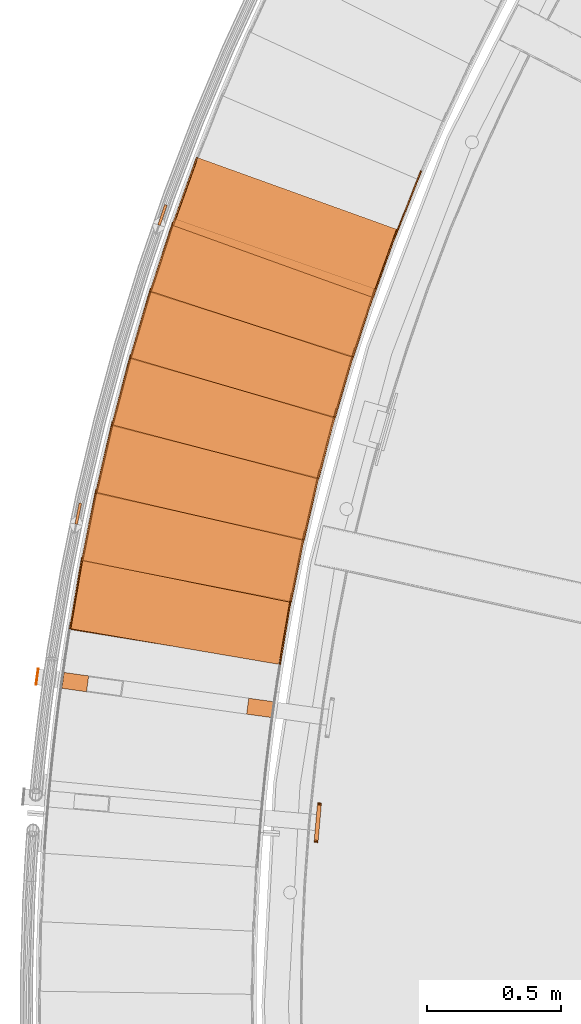
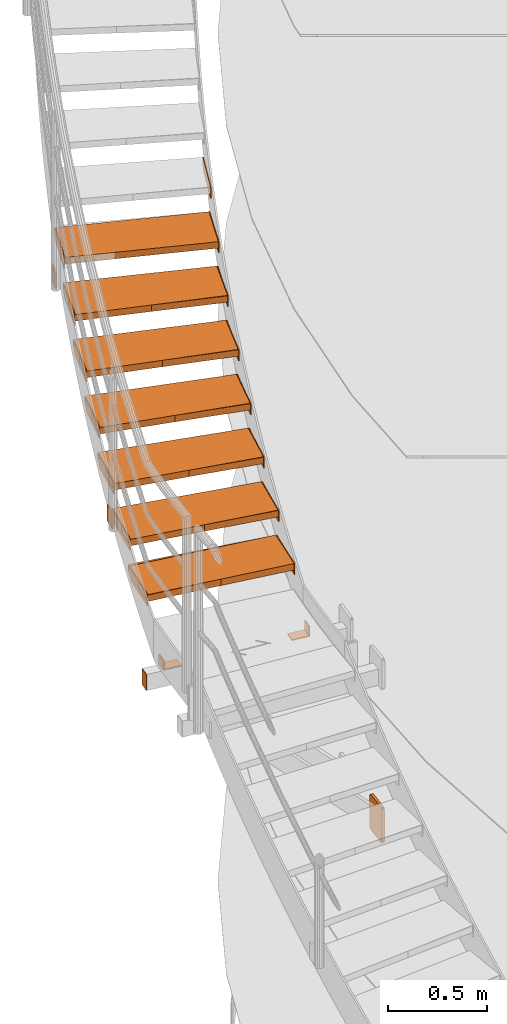
# One storey, part 61 of 126: 34 proxies.
"""IFC2X3 building model written with IfcOpenShell, lengths in millimetres."""

from ifc_helpers import new_model, si_unit, origin, origin_with_axes, place, context, project, spatial, faceted_brep, material, element, save


model = new_model("IFC2X3")

# Units and contexts
context_of_model_1 = context(None, 3, precision=0.1, world=origin())
context_of_model_2 = context(None, 3, precision=0.1, world=origin())
ifc_project = project(units=[si_unit("LENGTHUNIT", "METRE", prefix="MILLI"), si_unit("AREAUNIT", "SQUARE_METRE", prefix="CENTI"), si_unit("VOLUMEUNIT", "CUBIC_METRE", prefix="CENTI"), si_unit("MASSUNIT", "GRAM", prefix="KILO")], contexts=[context_of_model_1, context_of_model_2])

# Site, building, storey
site_placement = place(None, origin_with_axes())
site = spatial("IfcSite", under=ifc_project, at=site_placement, CompositionType="ELEMENT")
building_placement = place(site_placement, origin_with_axes())
building = spatial("IfcBuilding", under=site, at=building_placement, CompositionType="ELEMENT")
storey_placement = place(building_placement, origin_with_axes())
storey = spatial("IfcBuildingStorey", under=building, at=storey_placement, CompositionType="ELEMENT")

# Proxies
ifc_material_1 = material(Name="HOLZ")
proxy_1_placement = place(storey_placement, origin_with_axes())
element("IfcBuildingElementProxy", 1, at=proxy_1_placement, inside=storey, material=ifc_material_1, context=context_of_model_2, shape_type="Brep", body=[
    faceted_brep([(-647.8972, 9698.1797, 5715.8062), (-652.9137, 9672.3391, 5715.8062), (-657.8529, 9646.4836, 5715.8062), (-662.7149, 9620.6135, 5715.8062), (-667.4997, 9594.7289, 5715.8062), (-672.2071, 9568.8303, 5715.8062), (-676.8373, 9542.9176, 5715.8062), (-681.39, 9516.9913, 5715.8062), (-685.8653, 9491.0515, 5715.8062), (-690.2632, 9465.0984, 5715.8062), (-694.5835, 9439.1323, 5715.8062), (-698.8263, 9413.1535, 5715.8062), (90.905, 9285.3862, 5715.8062), (95.1968, 9311.638, 5715.8062), (99.5758, 9337.8754, 5715.8062), (104.0418, 9364.0982, 5715.8062), (108.5947, 9390.306, 5715.8062), (113.2346, 9416.4985, 5715.8062), (117.9614, 9442.6755, 5715.8062), (122.775, 9468.8366, 5715.8062), (127.6754, 9494.9817, 5715.8062), (132.6625, 9521.1103, 5715.8062), (137.7362, 9547.2223, 5715.8062), (-647.8972, 9698.1797, 5675.8062), (137.7362, 9547.2223, 5675.8062), (132.6625, 9521.1103, 5675.8062), (127.6754, 9494.9817, 5675.8062), (122.775, 9468.8366, 5675.8062), (117.9614, 9442.6755, 5675.8062), (113.2346, 9416.4985, 5675.8062), (108.5947, 9390.306, 5675.8062), (104.0418, 9364.0982, 5675.8062), (99.5758, 9337.8754, 5675.8062), (95.1968, 9311.638, 5675.8062), (90.905, 9285.3862, 5675.8062), (-698.8263, 9413.1535, 5675.8062), (-694.5835, 9439.1323, 5675.8062), (-690.2632, 9465.0984, 5675.8062), (-685.8653, 9491.0515, 5675.8062), (-681.39, 9516.9913, 5675.8062), (-676.8373, 9542.9176, 5675.8062), (-672.2071, 9568.8303, 5675.8062), (-667.4997, 9594.7289, 5675.8062), (-662.7149, 9620.6135, 5675.8062), (-657.8529, 9646.4836, 5675.8062), (-652.9137, 9672.3391, 5675.8062)], [[[0, 1, 2, 3, 4, 5, 6, 7, 8, 9, 10, 11, 12, 13, 14, 15, 16, 17, 18, 19, 20, 21, 22]], [[23, 24, 25, 26, 27, 28, 29, 30, 31, 32, 33, 34, 35, 36, 37, 38, 39, 40, 41, 42, 43, 44, 45]], [[0, 23, 45, 1]], [[1, 45, 44, 2]], [[2, 44, 43, 3]], [[3, 43, 42, 4]], [[4, 42, 41, 5]], [[5, 41, 40, 6]], [[6, 40, 39, 7]], [[7, 39, 38, 8]], [[8, 38, 37, 9]], [[9, 37, 36, 10]], [[10, 36, 35, 11]], [[11, 35, 34, 12]], [[12, 34, 33, 13]], [[13, 33, 32, 14]], [[14, 32, 31, 15]], [[15, 31, 30, 16]], [[16, 30, 29, 17]], [[17, 29, 28, 18]], [[18, 28, 27, 19]], [[19, 27, 26, 20]], [[20, 26, 25, 21]], [[21, 25, 24, 22]], [[22, 24, 23, 0]]]),
])
proxy_2_placement = place(storey_placement, origin_with_axes())
element("IfcBuildingElementProxy", 2, at=proxy_2_placement, inside=storey, material=ifc_material_1, context=context_of_model_2, shape_type="Brep", body=[
    faceted_brep([(-594.3119, 9952.1321, 5889.0125), (-600.0867, 9926.4503, 5889.0125), (-605.7848, 9900.7514, 5889.0125), (-611.4062, 9875.0356, 5889.0125), (-616.9507, 9849.3031, 5889.0125), (-622.4184, 9823.5542, 5889.0125), (-627.8093, 9797.7891, 5889.0125), (-633.1231, 9772.008, 5889.0125), (-638.36, 9746.2111, 5889.0125), (-643.5198, 9720.3987, 5889.0125), (-648.6026, 9694.5711, 5889.0125), (-653.6082, 9668.7283, 5889.0125), (132.0203, 9517.7718, 5889.0125), (137.083, 9543.8859, 5889.0125), (142.2323, 9569.9831, 5889.0125), (147.4681, 9596.063, 5889.0125), (152.7905, 9622.1254, 5889.0125), (158.1993, 9648.17, 5889.0125), (163.6946, 9674.1966, 5889.0125), (169.2761, 9700.2047, 5889.0125), (174.9439, 9726.1942, 5889.0125), (180.6979, 9752.1647, 5889.0125), (186.538, 9778.116, 5889.0125), (-594.3119, 9952.1321, 5849.0125), (186.538, 9778.116, 5849.0125), (180.6979, 9752.1647, 5849.0125), (174.9439, 9726.1942, 5849.0125), (169.2761, 9700.2047, 5849.0125), (163.6946, 9674.1966, 5849.0125), (158.1993, 9648.17, 5849.0125), (152.7905, 9622.1254, 5849.0125), (147.4681, 9596.063, 5849.0125), (142.2323, 9569.9831, 5849.0125), (137.083, 9543.8859, 5849.0125), (132.0203, 9517.7718, 5849.0125), (-653.6082, 9668.7283, 5849.0125), (-648.6026, 9694.5711, 5849.0125), (-643.5198, 9720.3987, 5849.0125), (-638.36, 9746.2111, 5849.0125), (-633.1231, 9772.008, 5849.0125), (-627.8093, 9797.7891, 5849.0125), (-622.4184, 9823.5542, 5849.0125), (-616.9507, 9849.3031, 5849.0125), (-611.4062, 9875.0356, 5849.0125), (-605.7848, 9900.7514, 5849.0125), (-600.0867, 9926.4503, 5849.0125)], [[[0, 1, 2, 3, 4, 5, 6, 7, 8, 9, 10, 11, 12, 13, 14, 15, 16, 17, 18, 19, 20, 21, 22]], [[23, 24, 25, 26, 27, 28, 29, 30, 31, 32, 33, 34, 35, 36, 37, 38, 39, 40, 41, 42, 43, 44, 45]], [[0, 23, 45, 1]], [[1, 45, 44, 2]], [[2, 44, 43, 3]], [[3, 43, 42, 4]], [[4, 42, 41, 5]], [[5, 41, 40, 6]], [[6, 40, 39, 7]], [[7, 39, 38, 8]], [[8, 38, 37, 9]], [[9, 37, 36, 10]], [[10, 36, 35, 11]], [[11, 35, 34, 12]], [[12, 34, 33, 13]], [[13, 33, 32, 14]], [[14, 32, 31, 15]], [[15, 31, 30, 16]], [[16, 30, 29, 17]], [[17, 29, 28, 18]], [[18, 28, 27, 19]], [[19, 27, 26, 20]], [[20, 26, 25, 21]], [[21, 25, 24, 22]], [[22, 24, 23, 0]]]),
])
proxy_3_placement = place(storey_placement, origin_with_axes())
element("IfcBuildingElementProxy", 3, at=proxy_3_placement, inside=storey, material=ifc_material_1, context=context_of_model_2, shape_type="Brep", body=[
    faceted_brep([(-533.275, 10204.397, 6062.2188), (-539.8032, 10178.897, 6062.2188), (-546.2552, 10153.377, 6062.2188), (-552.6311, 10127.837, 6062.2188), (-558.9306, 10102.279, 6062.2188), (-565.1539, 10076.702, 6062.2188), (-571.3007, 10051.107, 6062.2188), (-577.3711, 10025.494, 6062.2188), (-583.365, 9999.8619, 6062.2188), (-589.2824, 9974.2126, 6062.2188), (-595.1231, 9948.5458, 6062.2188), (-600.8872, 9922.8616, 6062.2188), (179.9577, 9748.8466, 6062.2188), (185.7868, 9774.8004, 6062.2188), (191.702, 9800.7347, 6062.2188), (197.7033, 9826.6492, 6062.2188), (203.7905, 9852.5436, 6062.2188), (209.9635, 9878.4178, 6062.2188), (216.2224, 9904.2713, 6062.2188), (222.567, 9930.1038, 6062.2188), (228.9973, 9955.9152, 6062.2188), (235.5132, 9981.7052, 6062.2188), (242.1147, 10007.473, 6062.2188), (-533.275, 10204.397, 6022.2188), (242.1147, 10007.473, 6022.2188), (235.5132, 9981.7052, 6022.2188), (228.9973, 9955.9152, 6022.2188), (222.567, 9930.1038, 6022.2188), (216.2224, 9904.2713, 6022.2188), (209.9635, 9878.4178, 6022.2188), (203.7905, 9852.5436, 6022.2188), (197.7033, 9826.6492, 6022.2188), (191.702, 9800.7347, 6022.2188), (185.7868, 9774.8004, 6022.2188), (179.9577, 9748.8466, 6022.2188), (-600.8872, 9922.8616, 6022.2188), (-595.1231, 9948.5458, 6022.2188), (-589.2824, 9974.2126, 6022.2188), (-583.365, 9999.8619, 6022.2188), (-577.3711, 10025.494, 6022.2188), (-571.3007, 10051.107, 6022.2188), (-565.1539, 10076.702, 6022.2188), (-558.9306, 10102.279, 6022.2188), (-552.6311, 10127.837, 6022.2188), (-546.2552, 10153.377, 6022.2188), (-539.8032, 10178.897, 6022.2188)], [[[0, 1, 2, 3, 4, 5, 6, 7, 8, 9, 10, 11, 12, 13, 14, 15, 16, 17, 18, 19, 20, 21, 22]], [[23, 24, 25, 26, 27, 28, 29, 30, 31, 32, 33, 34, 35, 36, 37, 38, 39, 40, 41, 42, 43, 44, 45]], [[0, 23, 45, 1]], [[1, 45, 44, 2]], [[2, 44, 43, 3]], [[3, 43, 42, 4]], [[4, 42, 41, 5]], [[5, 41, 40, 6]], [[6, 40, 39, 7]], [[7, 39, 38, 8]], [[8, 38, 37, 9]], [[9, 37, 36, 10]], [[10, 36, 35, 11]], [[11, 35, 34, 12]], [[12, 34, 33, 13]], [[13, 33, 32, 14]], [[14, 32, 31, 15]], [[15, 31, 30, 16]], [[16, 30, 29, 17]], [[17, 29, 28, 18]], [[18, 28, 27, 19]], [[19, 27, 26, 20]], [[20, 26, 25, 21]], [[21, 25, 24, 22]], [[22, 24, 23, 0]]]),
])
proxy_4_placement = place(storey_placement, origin_with_axes())
element("IfcBuildingElementProxy", 4, at=proxy_4_placement, inside=storey, material=ifc_material_1, context=context_of_model_2, shape_type="Brep", body=[
    faceted_brep([(-464.8394, 10454.757, 6235.425), (-472.1154, 10429.459, 6235.425), (-479.3158, 10404.14, 6235.425), (-486.4406, 10378.799, 6235.425), (-493.4897, 10353.438, 6235.425), (-500.4631, 10328.055, 6235.425), (-507.3606, 10302.652, 6235.425), (-514.1823, 10277.228, 6235.425), (-520.928, 10251.784, 6235.425), (-527.5977, 10226.32, 6235.425), (-534.1914, 10200.836, 6235.425), (-540.709, 10175.333, 6235.425), (234.6757, 9978.4103, 6235.425), (241.2662, 10004.181, 6235.425), (247.9422, 10029.93, 6235.425), (254.7036, 10055.657, 6235.425), (261.5503, 10081.361, 6235.425), (268.4823, 10107.042, 6235.425), (275.4994, 10132.7, 6235.425), (282.6016, 10158.335, 6235.425), (289.7889, 10183.946, 6235.425), (297.0611, 10209.533, 6235.425), (304.4181, 10235.095, 6235.425), (-464.8394, 10454.757, 6195.425), (304.4181, 10235.095, 6195.425), (297.0611, 10209.533, 6195.425), (289.7889, 10183.946, 6195.425), (282.6016, 10158.335, 6195.425), (275.4994, 10132.7, 6195.425), (268.4823, 10107.042, 6195.425), (261.5503, 10081.361, 6195.425), (254.7036, 10055.657, 6195.425), (247.9422, 10029.93, 6195.425), (241.2662, 10004.181, 6195.425), (234.6757, 9978.4103, 6195.425), (-540.709, 10175.333, 6195.425), (-534.1914, 10200.836, 6195.425), (-527.5977, 10226.32, 6195.425), (-520.928, 10251.784, 6195.425), (-514.1823, 10277.228, 6195.425), (-507.3606, 10302.652, 6195.425), (-500.4631, 10328.055, 6195.425), (-493.4897, 10353.438, 6195.425), (-486.4406, 10378.799, 6195.425), (-479.3158, 10404.14, 6195.425), (-472.1154, 10429.459, 6195.425)], [[[0, 1, 2, 3, 4, 5, 6, 7, 8, 9, 10, 11, 12, 13, 14, 15, 16, 17, 18, 19, 20, 21, 22]], [[23, 24, 25, 26, 27, 28, 29, 30, 31, 32, 33, 34, 35, 36, 37, 38, 39, 40, 41, 42, 43, 44, 45]], [[0, 23, 45, 1]], [[1, 45, 44, 2]], [[2, 44, 43, 3]], [[3, 43, 42, 4]], [[4, 42, 41, 5]], [[5, 41, 40, 6]], [[6, 40, 39, 7]], [[7, 39, 38, 8]], [[8, 38, 37, 9]], [[9, 37, 36, 10]], [[10, 36, 35, 11]], [[11, 35, 34, 12]], [[12, 34, 33, 13]], [[13, 33, 32, 14]], [[14, 32, 31, 15]], [[15, 31, 30, 16]], [[16, 30, 29, 17]], [[17, 29, 28, 18]], [[18, 28, 27, 19]], [[19, 27, 26, 20]], [[20, 26, 25, 21]], [[21, 25, 24, 22]], [[22, 24, 23, 0]]]),
])
proxy_5_placement = place(storey_placement, origin_with_axes())
element("IfcBuildingElementProxy", 5, at=proxy_5_placement, inside=storey, material=ifc_material_1, context=context_of_model_2, shape_type="Brep", body=[
    faceted_brep([(-389.0646, 10702.993, 6408.6313), (-397.082, 10677.921, 6408.6313), (-405.0245, 10652.825, 6408.6313), (-412.8921, 10627.705, 6408.6313), (-420.6846, 10602.562, 6408.6313), (-428.4021, 10577.395, 6408.6313), (-436.0443, 10552.206, 6408.6313), (-443.6113, 10526.994, 6408.6313), (-451.1031, 10501.76, 6408.6313), (-458.5194, 10476.503, 6408.6313), (-465.8603, 10451.224, 6408.6313), (-473.1257, 10425.924, 6408.6313), (296.1269, 10206.264, 6408.6313), (303.4731, 10231.83, 6408.6313), (310.9041, 10257.371, 6408.6313), (318.4198, 10282.888, 6408.6313), (326.0201, 10308.379, 6408.6313), (333.7049, 10333.845, 6408.6313), (341.4742, 10359.285, 6408.6313), (349.3279, 10384.7, 6408.6313), (357.2658, 10410.088, 6408.6313), (365.288, 10435.45, 6408.6313), (373.3942, 10460.785, 6408.6313), (-389.0646, 10702.993, 6368.6313), (373.3942, 10460.785, 6368.6313), (365.288, 10435.45, 6368.6313), (357.2658, 10410.088, 6368.6313), (349.3279, 10384.7, 6368.6313), (341.4742, 10359.285, 6368.6313), (333.7049, 10333.845, 6368.6313), (326.0201, 10308.379, 6368.6313), (318.4198, 10282.888, 6368.6313), (310.9041, 10257.371, 6368.6313), (303.4731, 10231.83, 6368.6313), (296.1269, 10206.264, 6368.6313), (-473.1257, 10425.924, 6368.6313), (-465.8603, 10451.224, 6368.6313), (-458.5194, 10476.503, 6368.6313), (-451.1031, 10501.76, 6368.6313), (-443.6113, 10526.994, 6368.6313), (-436.0443, 10552.206, 6368.6313), (-428.4021, 10577.395, 6368.6313), (-420.6846, 10602.562, 6368.6313), (-412.8921, 10627.705, 6368.6313), (-405.0245, 10652.825, 6368.6313), (-397.082, 10677.921, 6368.6313)], [[[0, 1, 2, 3, 4, 5, 6, 7, 8, 9, 10, 11, 12, 13, 14, 15, 16, 17, 18, 19, 20, 21, 22]], [[23, 24, 25, 26, 27, 28, 29, 30, 31, 32, 33, 34, 35, 36, 37, 38, 39, 40, 41, 42, 43, 44, 45]], [[0, 23, 45, 1]], [[1, 45, 44, 2]], [[2, 44, 43, 3]], [[3, 43, 42, 4]], [[4, 42, 41, 5]], [[5, 41, 40, 6]], [[6, 40, 39, 7]], [[7, 39, 38, 8]], [[8, 38, 37, 9]], [[9, 37, 36, 10]], [[10, 36, 35, 11]], [[11, 35, 34, 12]], [[12, 34, 33, 13]], [[13, 33, 32, 14]], [[14, 32, 31, 15]], [[15, 31, 30, 16]], [[16, 30, 29, 17]], [[17, 29, 28, 18]], [[18, 28, 27, 19]], [[19, 27, 26, 20]], [[20, 26, 25, 21]], [[21, 25, 24, 22]], [[22, 24, 23, 0]]]),
])
proxy_6_placement = place(storey_placement, origin_with_axes())
element("IfcBuildingElementProxy", 6, at=proxy_6_placement, inside=storey, material=ifc_material_1, context=context_of_model_2, shape_type="Brep", body=[
    faceted_brep([(-306.0161, 10948.892, 6581.8375), (-314.768, 10924.066, 6581.8375), (-323.4458, 10899.215, 6581.8375), (-332.0493, 10874.337, 6581.8375), (-340.5785, 10849.434, 6581.8375), (-349.0333, 10824.506, 6581.8375), (-357.4137, 10799.553, 6581.8375), (-365.7195, 10774.574, 6581.8375), (-373.9507, 10749.571, 6581.8375), (-382.1072, 10724.544, 6581.8375), (-390.189, 10699.492, 6581.8375), (-398.196, 10674.416, 6581.8375), (364.258, 10432.21, 6581.8375), (372.3535, 10457.549, 6581.8375), (380.5331, 10482.86, 6581.8375), (388.7965, 10508.144, 6581.8375), (397.1438, 10533.401, 6581.8375), (405.5749, 10558.63, 6581.8375), (414.0897, 10583.831, 6581.8375), (422.688, 10609.003, 6581.8375), (431.3697, 10634.147, 6581.8375), (440.1349, 10659.261, 6581.8375), (448.9833, 10684.347, 6581.8375), (-306.0161, 10948.892, 6541.8375), (448.9833, 10684.347, 6541.8375), (440.1349, 10659.261, 6541.8375), (431.3697, 10634.147, 6541.8375), (422.688, 10609.003, 6541.8375), (414.0897, 10583.831, 6541.8375), (405.5749, 10558.63, 6541.8375), (397.1438, 10533.401, 6541.8375), (388.7965, 10508.144, 6541.8375), (380.5331, 10482.86, 6541.8375), (372.3535, 10457.549, 6541.8375), (364.258, 10432.21, 6541.8375), (-398.196, 10674.416, 6541.8375), (-390.189, 10699.492, 6541.8375), (-382.1072, 10724.544, 6541.8375), (-373.9507, 10749.571, 6541.8375), (-365.7195, 10774.574, 6541.8375), (-357.4137, 10799.553, 6541.8375), (-349.0333, 10824.506, 6541.8375), (-340.5785, 10849.434, 6541.8375), (-332.0493, 10874.337, 6541.8375), (-323.4458, 10899.215, 6541.8375), (-314.768, 10924.066, 6541.8375)], [[[0, 1, 2, 3, 4, 5, 6, 7, 8, 9, 10, 11, 12, 13, 14, 15, 16, 17, 18, 19, 20, 21, 22]], [[23, 24, 25, 26, 27, 28, 29, 30, 31, 32, 33, 34, 35, 36, 37, 38, 39, 40, 41, 42, 43, 44, 45]], [[0, 23, 45, 1]], [[1, 45, 44, 2]], [[2, 44, 43, 3]], [[3, 43, 42, 4]], [[4, 42, 41, 5]], [[5, 41, 40, 6]], [[6, 40, 39, 7]], [[7, 39, 38, 8]], [[8, 38, 37, 9]], [[9, 37, 36, 10]], [[10, 36, 35, 11]], [[11, 35, 34, 12]], [[12, 34, 33, 13]], [[13, 33, 32, 14]], [[14, 32, 31, 15]], [[15, 31, 30, 16]], [[16, 30, 29, 17]], [[17, 29, 28, 18]], [[18, 28, 27, 19]], [[19, 27, 26, 20]], [[20, 26, 25, 21]], [[21, 25, 24, 22]], [[22, 24, 23, 0]]]),
])
ifc_material_2 = material(Name="S235JRG2")
proxy_7_placement = place(storey_placement, origin_with_axes())
element("IfcBuildingElementProxy", 7, at=proxy_7_placement, inside=storey, material=ifc_material_2, context=context_of_model_2, shape_type="Brep", body=[
    faceted_brep([(-693.3253, 9415.7549, 5675.81), (-693.3253, 9415.7549, 5715.81), (-647.8797, 9681.9028, 5715.81), (-647.8797, 9681.9028, 5675.81), (85.4037, 9282.7844, 5675.81), (130.8493, 9548.9322, 5675.81), (130.8493, 9548.9322, 5715.81), (85.4037, 9282.7844, 5715.81)], [[[0, 1, 2, 3]], [[4, 5, 6, 7]], [[0, 4, 7, 1]], [[1, 7, 6, 2]], [[2, 6, 5, 3]], [[3, 5, 4, 0]]]),
])
proxy_8_placement = place(storey_placement, origin_with_axes())
element("IfcBuildingElementProxy", 8, at=proxy_8_placement, inside=storey, material=ifc_material_2, context=context_of_model_2, shape_type="Brep", body=[
    faceted_brep([(85.4037, 9282.7844, 5645.81), (90.3323, 9281.9428, 5645.81), (90.3323, 9281.9428, 5715.81), (85.4037, 9282.7844, 5715.81), (130.8493, 9548.9322, 5715.81), (135.7779, 9548.0907, 5715.81), (135.7779, 9548.0907, 5675.81), (130.8493, 9548.9322, 5675.81), (125.7998, 9519.3603, 5645.81), (130.7284, 9518.5187, 5645.81)], [[[0, 1, 2, 3]], [[4, 5, 6, 7]], [[0, 8, 9, 1]], [[1, 9, 6, 5, 2]], [[2, 5, 4, 3]], [[0, 3, 4, 7, 8]], [[6, 9, 8, 7]]]),
])
proxy_9_placement = place(storey_placement, origin_with_axes())
element("IfcBuildingElementProxy", 9, at=proxy_9_placement, inside=storey, material=ifc_material_2, context=context_of_model_2, shape_type="Brep", body=[
    faceted_brep([(-698.254, 9416.5965, 5645.81), (-693.3253, 9415.7549, 5645.81), (-693.3253, 9415.7549, 5715.81), (-698.254, 9416.5965, 5715.81), (-652.8084, 9682.7444, 5715.81), (-647.8797, 9681.9028, 5715.81), (-647.8797, 9681.9028, 5675.81), (-652.8084, 9682.7444, 5675.81), (-657.8579, 9653.1724, 5645.81), (-652.9292, 9652.3308, 5645.81)], [[[0, 1, 2, 3]], [[4, 5, 6, 7]], [[0, 8, 9, 1]], [[1, 9, 6, 5, 2]], [[2, 5, 4, 3]], [[0, 3, 4, 7, 8]], [[6, 9, 8, 7]]]),
])
proxy_10_placement = place(storey_placement, origin_with_axes())
element("IfcBuildingElementProxy", 10, at=proxy_10_placement, inside=storey, material=ifc_material_2, context=context_of_model_2, shape_type="Brep", body=[
    faceted_brep([(-648.0332, 9671.166, 5848.97), (-648.0332, 9671.166, 5888.97), (-594.7736, 9935.8609, 5888.97), (-594.7736, 9935.8609, 5848.97), (126.4446, 9515.3323, 5848.97), (179.7042, 9780.0273, 5848.97), (179.7042, 9780.0273, 5888.97), (126.4446, 9515.3323, 5888.97)], [[[0, 1, 2, 3]], [[4, 5, 6, 7]], [[0, 4, 7, 1]], [[1, 7, 6, 2]], [[2, 6, 5, 3]], [[3, 5, 4, 0]]]),
])
proxy_11_placement = place(storey_placement, origin_with_axes())
element("IfcBuildingElementProxy", 11, at=proxy_11_placement, inside=storey, material=ifc_material_2, context=context_of_model_2, shape_type="Brep", body=[
    faceted_brep([(126.4446, 9515.3323, 5818.97), (131.3464, 9514.346, 5818.97), (131.3464, 9514.346, 5888.97), (126.4446, 9515.3323, 5888.97), (179.7042, 9780.0273, 5888.97), (184.606, 9779.041, 5888.97), (184.606, 9779.041, 5848.97), (179.7042, 9780.0273, 5848.97), (173.7865, 9750.6167, 5818.97), (178.6882, 9749.6304, 5818.97)], [[[0, 1, 2, 3]], [[4, 5, 6, 7]], [[0, 8, 9, 1]], [[1, 9, 6, 5, 2]], [[2, 5, 4, 3]], [[0, 3, 4, 7, 8]], [[6, 9, 8, 7]]]),
])
proxy_12_placement = place(storey_placement, origin_with_axes())
element("IfcBuildingElementProxy", 12, at=proxy_12_placement, inside=storey, material=ifc_material_2, context=context_of_model_2, shape_type="Brep", body=[
    faceted_brep([(-652.935, 9672.1523, 5818.97), (-648.0332, 9671.166, 5818.97), (-648.0332, 9671.166, 5888.97), (-652.935, 9672.1523, 5888.97), (-599.6754, 9936.8472, 5888.97), (-594.7736, 9935.8609, 5888.97), (-594.7736, 9935.8609, 5848.97), (-599.6754, 9936.8472, 5848.97), (-605.5931, 9907.4367, 5818.97), (-600.6913, 9906.4504, 5818.97)], [[[0, 1, 2, 3]], [[4, 5, 6, 7]], [[0, 8, 9, 1]], [[1, 9, 6, 5, 2]], [[2, 5, 4, 3]], [[0, 3, 4, 7, 8]], [[6, 9, 8, 7]]]),
])
proxy_13_placement = place(storey_placement, origin_with_axes())
element("IfcBuildingElementProxy", 13, at=proxy_13_placement, inside=storey, material=ifc_material_2, context=context_of_model_2, shape_type="Brep", body=[
    faceted_brep([(-595.2431, 9925.1333, 6022.13), (-595.2431, 9925.1333, 6062.13), (-534.2156, 10188.146, 6062.13), (-534.2156, 10188.146, 6022.13), (174.3124, 9746.5716, 6022.13), (235.3399, 10009.584, 6022.13), (235.3399, 10009.584, 6062.13), (174.3124, 9746.5716, 6062.13)], [[[0, 1, 2, 3]], [[4, 5, 6, 7]], [[0, 4, 7, 1]], [[1, 7, 6, 2]], [[2, 6, 5, 3]], [[3, 5, 4, 0]]]),
])
proxy_14_placement = place(storey_placement, origin_with_axes())
element("IfcBuildingElementProxy", 14, at=proxy_14_placement, inside=storey, material=ifc_material_2, context=context_of_model_2, shape_type="Brep", body=[
    faceted_brep([(174.3124, 9746.5716, 5992.13), (179.1831, 9745.4414, 5992.13), (179.1831, 9745.4414, 6062.13), (174.3124, 9746.5716, 6062.13), (235.3399, 10009.584, 6062.13), (240.2105, 10008.454, 6062.13), (240.2105, 10008.454, 6022.13), (235.3399, 10009.584, 6022.13), (228.5591, 9980.3606, 5992.13), (233.4297, 9979.2305, 5992.13)], [[[0, 1, 2, 3]], [[4, 5, 6, 7]], [[0, 8, 9, 1]], [[1, 9, 6, 5, 2]], [[2, 5, 4, 3]], [[0, 3, 4, 7, 8]], [[6, 9, 8, 7]]]),
])
proxy_15_placement = place(storey_placement, origin_with_axes())
element("IfcBuildingElementProxy", 15, at=proxy_15_placement, inside=storey, material=ifc_material_2, context=context_of_model_2, shape_type="Brep", body=[
    faceted_brep([(-600.1137, 9926.2635, 5992.13), (-595.2431, 9925.1333, 5992.13), (-595.2431, 9925.1333, 6062.13), (-600.1137, 9926.2635, 6062.13), (-539.0862, 10189.276, 6062.13), (-534.2156, 10188.146, 6062.13), (-534.2156, 10188.146, 6022.13), (-539.0862, 10189.276, 6022.13), (-545.8671, 10160.053, 5992.13), (-540.9965, 10158.922, 5992.13)], [[[0, 1, 2, 3]], [[4, 5, 6, 7]], [[0, 8, 9, 1]], [[1, 9, 6, 5, 2]], [[2, 5, 4, 3]], [[0, 3, 4, 7, 8]], [[6, 9, 8, 7]]]),
])
proxy_16_placement = place(storey_placement, origin_with_axes())
element("IfcBuildingElementProxy", 16, at=proxy_16_placement, inside=storey, material=ifc_material_2, context=context_of_model_2, shape_type="Brep", body=[
    faceted_brep([(-535.0007, 10177.437, 6195.29), (-535.0007, 10177.437, 6235.29), (-466.2583, 10438.539, 6235.29), (-466.2583, 10438.539, 6195.29), (228.9658, 9976.3017, 6195.29), (297.7081, 10237.404, 6195.29), (297.7081, 10237.404, 6235.29), (228.9658, 9976.3017, 6235.29)], [[[0, 1, 2, 3]], [[4, 5, 6, 7]], [[0, 4, 7, 1]], [[1, 7, 6, 2]], [[2, 6, 5, 3]], [[3, 5, 4, 0]]]),
])
proxy_17_placement = place(storey_placement, origin_with_axes())
element("IfcBuildingElementProxy", 17, at=proxy_17_placement, inside=storey, material=ifc_material_2, context=context_of_model_2, shape_type="Brep", body=[
    faceted_brep([(228.9658, 9976.3017, 6165.29), (233.801, 9975.0287, 6165.29), (233.801, 9975.0287, 6235.29), (228.9658, 9976.3017, 6235.29), (297.7081, 10237.404, 6235.29), (302.5434, 10236.131, 6235.29), (302.5434, 10236.131, 6195.29), (297.7081, 10237.404, 6195.29), (290.0701, 10208.393, 6165.29), (294.9053, 10207.12, 6165.29)], [[[0, 1, 2, 3]], [[4, 5, 6, 7]], [[0, 8, 9, 1]], [[1, 9, 6, 5, 2]], [[2, 5, 4, 3]], [[0, 3, 4, 7, 8]], [[6, 9, 8, 7]]]),
])
proxy_18_placement = place(storey_placement, origin_with_axes())
element("IfcBuildingElementProxy", 18, at=proxy_18_placement, inside=storey, material=ifc_material_2, context=context_of_model_2, shape_type="Brep", body=[
    faceted_brep([(-539.8359, 10178.71, 6165.29), (-535.0007, 10177.437, 6165.29), (-535.0007, 10177.437, 6235.29), (-539.8359, 10178.71, 6235.29), (-471.0935, 10439.812, 6235.29), (-466.2583, 10438.539, 6235.29), (-466.2583, 10438.539, 6195.29), (-471.0935, 10439.812, 6195.29), (-478.7315, 10410.801, 6165.29), (-473.8963, 10409.528, 6165.29)], [[[0, 1, 2, 3]], [[4, 5, 6, 7]], [[0, 8, 9, 1]], [[1, 9, 6, 5, 2]], [[2, 5, 4, 3]], [[0, 3, 4, 7, 8]], [[6, 9, 8, 7]]]),
])
proxy_19_placement = place(storey_placement, origin_with_axes())
element("IfcBuildingElementProxy", 19, at=proxy_19_placement, inside=storey, material=ifc_material_2, context=context_of_model_2, shape_type="Brep", body=[
    faceted_brep([(-467.3582, 10427.858, 6368.45), (-467.3582, 10427.858, 6408.45), (-390.9604, 10686.824, 6408.45), (-390.9604, 10686.824, 6368.45), (290.3571, 10204.324, 6368.45), (366.7549, 10463.29, 6368.45), (366.7549, 10463.29, 6408.45), (290.3571, 10204.324, 6408.45)], [[[0, 1, 2, 3]], [[4, 5, 6, 7]], [[0, 4, 7, 1]], [[1, 7, 6, 2]], [[2, 6, 5, 3]], [[3, 5, 4, 0]]]),
])
proxy_20_placement = place(storey_placement, origin_with_axes())
element("IfcBuildingElementProxy", 20, at=proxy_20_placement, inside=storey, material=ifc_material_2, context=context_of_model_2, shape_type="Brep", body=[
    faceted_brep([(290.3571, 10204.324, 6338.45), (295.1528, 10202.909, 6338.45), (295.1528, 10202.909, 6408.45), (290.3571, 10204.324, 6408.45), (366.7549, 10463.29, 6408.45), (371.5506, 10461.875, 6408.45), (371.5506, 10461.875, 6368.45), (366.7549, 10463.29, 6368.45), (358.2663, 10434.516, 6338.45), (363.0619, 10433.101, 6338.45)], [[[0, 1, 2, 3]], [[4, 5, 6, 7]], [[0, 8, 9, 1]], [[1, 9, 6, 5, 2]], [[2, 5, 4, 3]], [[0, 3, 4, 7, 8]], [[6, 9, 8, 7]]]),
])
proxy_21_placement = place(storey_placement, origin_with_axes())
element("IfcBuildingElementProxy", 21, at=proxy_21_placement, inside=storey, material=ifc_material_2, context=context_of_model_2, shape_type="Brep", body=[
    faceted_brep([(-472.1538, 10429.273, 6338.45), (-467.3582, 10427.858, 6338.45), (-467.3582, 10427.858, 6408.45), (-472.1538, 10429.273, 6408.45), (-395.7561, 10688.239, 6408.45), (-390.9604, 10686.824, 6408.45), (-390.9604, 10686.824, 6368.45), (-395.7561, 10688.239, 6368.45), (-404.2447, 10659.465, 6338.45), (-399.449, 10658.05, 6338.45)], [[[0, 1, 2, 3]], [[4, 5, 6, 7]], [[0, 8, 9, 1]], [[1, 9, 6, 5, 2]], [[2, 5, 4, 3]], [[0, 3, 4, 7, 8]], [[6, 9, 8, 7]]]),
])
proxy_22_placement = place(storey_placement, origin_with_axes())
element("IfcBuildingElementProxy", 22, at=proxy_22_placement, inside=storey, material=ifc_material_2, context=context_of_model_2, shape_type="Brep", body=[
    faceted_brep([(-392.3742, 10676.179, 6541.61), (-392.3742, 10676.179, 6581.61), (-308.3873, 10932.785, 6581.61), (-308.3873, 10932.785, 6541.61), (358.4334, 10430.44, 6541.61), (442.4204, 10687.045, 6541.61), (442.4204, 10687.045, 6581.61), (358.4334, 10430.44, 6581.61)], [[[0, 1, 2, 3]], [[4, 5, 6, 7]], [[0, 4, 7, 1]], [[1, 7, 6, 2]], [[2, 6, 5, 3]], [[3, 5, 4, 0]]]),
])
proxy_23_placement = place(storey_placement, origin_with_axes())
element("IfcBuildingElementProxy", 23, at=proxy_23_placement, inside=storey, material=ifc_material_2, context=context_of_model_2, shape_type="Brep", body=[
    faceted_brep([(358.4334, 10430.44, 6511.61), (363.1854, 10428.885, 6511.61), (363.1854, 10428.885, 6581.61), (358.4334, 10430.44, 6581.61), (442.4204, 10687.045, 6581.61), (447.1723, 10685.49, 6581.61), (447.1723, 10685.49, 6541.61), (442.4204, 10687.045, 6541.61), (433.0885, 10658.533, 6511.61), (437.8404, 10656.978, 6511.61)], [[[0, 1, 2, 3]], [[4, 5, 6, 7]], [[0, 8, 9, 1]], [[1, 9, 6, 5, 2]], [[2, 5, 4, 3]], [[0, 3, 4, 7, 8]], [[6, 9, 8, 7]]]),
])
proxy_24_placement = place(storey_placement, origin_with_axes())
element("IfcBuildingElementProxy", 24, at=proxy_24_placement, inside=storey, material=ifc_material_2, context=context_of_model_2, shape_type="Brep", body=[
    faceted_brep([(-397.1261, 10677.735, 6511.61), (-392.3742, 10676.179, 6511.61), (-392.3742, 10676.179, 6581.61), (-397.1261, 10677.735, 6581.61), (-313.1392, 10934.34, 6581.61), (-308.3873, 10932.785, 6581.61), (-308.3873, 10932.785, 6541.61), (-313.1392, 10934.34, 6541.61), (-322.4711, 10905.828, 6511.61), (-317.7191, 10904.273, 6511.61)], [[[0, 1, 2, 3]], [[4, 5, 6, 7]], [[0, 8, 9, 1]], [[1, 9, 6, 5, 2]], [[2, 5, 4, 3]], [[0, 3, 4, 7, 8]], [[6, 9, 8, 7]]]),
])
proxy_25_placement = place(storey_placement, origin_with_axes())
element("IfcBuildingElementProxy", 25, at=proxy_25_placement, inside=storey, material=ifc_material_2, context=context_of_model_2, shape_type="Brep", body=[
    faceted_brep([(-310.1137, 10922.186, 6714.77), (-310.1137, 10922.186, 6754.77), (-218.6104, 11176.208, 6754.77), (-218.6104, 11176.208, 6714.77), (433.1356, 10654.454, 6714.77), (524.6389, 10908.476, 6714.77), (524.6389, 10908.476, 6754.77), (433.1356, 10654.454, 6754.77)], [[[0, 1, 2, 3]], [[4, 5, 6, 7]], [[0, 4, 7, 1]], [[1, 7, 6, 2]], [[2, 6, 5, 3]], [[3, 5, 4, 0]]]),
])
proxy_26_placement = place(storey_placement, origin_with_axes())
element("IfcBuildingElementProxy", 26, at=proxy_26_placement, inside=storey, material=ifc_material_2, context=context_of_model_2, shape_type="Brep", body=[
    faceted_brep([(433.1356, 10654.454, 6684.77), (437.8397, 10652.76, 6684.77), (437.8397, 10652.76, 6754.77), (433.1356, 10654.454, 6754.77), (524.6389, 10908.476, 6754.77), (529.3431, 10906.782, 6754.77), (529.3431, 10906.782, 6714.77), (524.6389, 10908.476, 6714.77), (514.4719, 10880.252, 6684.77), (519.176, 10878.557, 6684.77)], [[[0, 1, 2, 3]], [[4, 5, 6, 7]], [[0, 8, 9, 1]], [[1, 9, 6, 5, 2]], [[2, 5, 4, 3]], [[0, 3, 4, 7, 8]], [[6, 9, 8, 7]]]),
])
proxy_27_placement = place(storey_placement, origin_with_axes())
element("IfcBuildingElementProxy", 27, at=proxy_27_placement, inside=storey, material=ifc_material_2, context=context_of_model_2, shape_type="Brep", body=[
    faceted_brep([(-314.8178, 10923.881, 6684.77), (-310.1137, 10922.186, 6684.77), (-310.1137, 10922.186, 6754.77), (-314.8178, 10923.881, 6754.77), (-223.3145, 11177.903, 6754.77), (-218.6104, 11176.208, 6754.77), (-218.6104, 11176.208, 6714.77), (-223.3145, 11177.903, 6714.77), (-233.4815, 11149.678, 6684.77), (-228.7774, 11147.984, 6684.77)], [[[0, 1, 2, 3]], [[4, 5, 6, 7]], [[0, 8, 9, 1]], [[1, 9, 6, 5, 2]], [[2, 5, 4, 3]], [[0, 3, 4, 7, 8]], [[6, 9, 8, 7]]]),
])
proxy_28_placement = place(storey_placement, origin_with_axes())
element("IfcBuildingElementProxy", 28, at=proxy_28_placement, inside=storey, material=ifc_material_2, context=context_of_model_2, shape_type="Brep", body=[
    faceted_brep([(514.399, 10876.173, 6857.93), (519.0512, 10874.341, 6857.93), (519.0512, 10874.341, 6927.93), (514.399, 10876.173, 6927.93), (613.3394, 11127.392, 6927.93), (617.9916, 11125.559, 6927.93), (617.9916, 11125.559, 6887.93), (613.3394, 11127.392, 6887.93), (602.346, 11099.478, 6857.93), (606.9982, 11097.646, 6857.93)], [[[0, 1, 2, 3]], [[4, 5, 6, 7]], [[0, 8, 9, 1]], [[1, 9, 6, 5, 2]], [[2, 5, 4, 3]], [[0, 3, 4, 7, 8]], [[6, 9, 8, 7]]]),
])
proxy_29_placement = place(storey_placement, origin_with_axes())
element("IfcBuildingElementProxy", 29, at=proxy_29_placement, inside=storey, material=ifc_material_2, context=context_of_model_2, shape_type="Brep", body=[
    faceted_brep([(-815.9948, 9266.3671, 5292.5501), (-813.0236, 9265.9524, 5292.5501), (-821.3169, 9206.5284, 5292.5501), (-824.2881, 9206.943, 5292.5501), (-815.9948, 9266.3671, 5392.55), (-824.2881, 9206.943, 5392.55), (-821.3169, 9206.5284, 5392.55), (-813.0236, 9265.9524, 5392.55)], [[[0, 1, 2, 3]], [[4, 5, 6, 7]], [[0, 4, 7, 1]], [[1, 7, 6, 2]], [[2, 6, 5, 3]], [[3, 5, 4, 0]]]),
])
proxy_30_placement = place(storey_placement, origin_with_axes())
element("IfcBuildingElementProxy", 30, at=proxy_30_placement, inside=storey, material=ifc_material_2, context=context_of_model_2, shape_type="Brep", body=[
    faceted_brep([(62.776, 9083.1425, 5457.55), (62.776, 9083.1425, 5392.55), (71.0694, 9142.5666, 5392.55), (71.0694, 9142.5666, 5457.55), (64.1366, 9143.5341, 5457.55), (55.8432, 9084.1101, 5457.55), (64.1366, 9143.5341, 5399.55), (55.8432, 9084.1101, 5399.55), (-27.9708, 9156.3888, 5399.55), (-36.2641, 9096.9647, 5399.55), (-27.9708, 9156.3888, 5392.55), (-36.2641, 9096.9647, 5392.55)], [[[0, 1, 2, 3]], [[0, 3, 4, 5]], [[5, 4, 6, 7]], [[7, 6, 8, 9]], [[9, 8, 10, 11]], [[1, 11, 10, 2]], [[1, 0, 5, 7, 9, 11]], [[3, 2, 10, 8, 6, 4]]]),
])
proxy_31_placement = place(storey_placement, origin_with_axes())
element("IfcBuildingElementProxy", 31, at=proxy_31_placement, inside=storey, material=ifc_material_2, context=context_of_model_2, shape_type="Brep", body=[
    faceted_brep([(-733.3576, 9194.2526, 5457.55), (-725.0643, 9253.6766, 5457.55), (-725.0643, 9253.6766, 5392.55), (-733.3576, 9194.2526, 5392.55), (-726.4248, 9193.285, 5457.55), (-718.1315, 9252.7091, 5457.55), (-726.4248, 9193.285, 5399.55), (-718.1315, 9252.7091, 5399.55), (-634.3175, 9180.4303, 5399.55), (-626.0241, 9239.8544, 5399.55), (-634.3175, 9180.4303, 5392.55), (-626.0241, 9239.8544, 5392.55)], [[[0, 1, 2, 3]], [[0, 4, 5, 1]], [[4, 6, 7, 5]], [[6, 8, 9, 7]], [[8, 10, 11, 9]], [[3, 2, 11, 10]], [[3, 10, 8, 6, 4, 0]], [[1, 5, 7, 9, 11, 2]]]),
])
proxy_32_placement = place(storey_placement, origin_with_axes())
element("IfcBuildingElementProxy", 32, at=proxy_32_placement, inside=storey, material=ifc_material_2, context=context_of_model_2, shape_type="Brep", body=[
    faceted_brep([(242.4863, 8750.5091, 4337.8773), (242.9911, 8756.2271, 4339.0191), (243.419, 8761.0746, 4342.2707), (243.7049, 8764.3136, 4347.137), (243.8054, 8765.4509, 4352.8773), (243.8054, 8765.4509, 4542.8773), (243.7049, 8764.3136, 4548.6175), (243.419, 8761.0746, 4553.4839), (242.9911, 8756.2271, 4556.7355), (242.4863, 8750.5091, 4557.8773), (231.9337, 8630.9739, 4557.8773), (231.4289, 8625.2559, 4556.7355), (231.001, 8620.4084, 4553.4839), (230.715, 8617.1694, 4548.6175), (230.6146, 8616.032, 4542.8773), (230.6146, 8616.032, 4352.8773), (230.715, 8617.1694, 4347.137), (231.001, 8620.4084, 4342.2707), (231.4289, 8625.2559, 4339.0191), (231.9337, 8630.9739, 4337.8773), (227.5444, 8751.8281, 4337.8773), (216.9918, 8632.293, 4337.8773), (216.487, 8626.575, 4339.0191), (216.0591, 8621.7275, 4342.2707), (215.7732, 8618.4885, 4347.137), (215.6727, 8617.3511, 4352.8773), (215.6727, 8617.3511, 4542.8773), (215.7732, 8618.4885, 4548.6175), (216.0591, 8621.7275, 4553.4839), (216.487, 8626.575, 4556.7355), (216.9918, 8632.293, 4557.8773), (227.5444, 8751.8281, 4557.8773), (228.0492, 8757.5461, 4556.7355), (228.4771, 8762.3936, 4553.4839), (228.7631, 8765.6326, 4548.6175), (228.8635, 8766.77, 4542.8773), (228.8635, 8766.77, 4352.8773), (228.7631, 8765.6326, 4347.137), (228.4771, 8762.3936, 4342.2707), (228.0492, 8757.5461, 4339.0191)], [[[0, 1, 2, 3, 4, 5, 6, 7, 8, 9, 10, 11, 12, 13, 14, 15, 16, 17, 18, 19]], [[20, 21, 22, 23, 24, 25, 26, 27, 28, 29, 30, 31, 32, 33, 34, 35, 36, 37, 38, 39]], [[0, 20, 39, 1]], [[1, 39, 38, 2]], [[2, 38, 37, 3]], [[3, 37, 36, 4]], [[4, 36, 35, 5]], [[5, 35, 34, 6]], [[6, 34, 33, 7]], [[7, 33, 32, 8]], [[8, 32, 31, 9]], [[9, 31, 30, 10]], [[10, 30, 29, 11]], [[11, 29, 28, 12]], [[12, 28, 27, 13]], [[13, 27, 26, 14]], [[14, 26, 25, 15]], [[15, 25, 24, 16]], [[16, 24, 23, 17]], [[17, 23, 22, 18]], [[18, 22, 21, 19]], [[19, 21, 20, 0]]]),
])
proxy_33_placement = place(storey_placement, origin_with_axes())
element("IfcBuildingElementProxy", 33, at=proxy_33_placement, inside=storey, material=ifc_material_2, Name="HANDLAUF", context=context_of_model_2, shape_type="Brep", body=[
    faceted_brep([(-662.0185, 9886.1733, 5876.4049), (-652.2146, 9884.2026, 5876.4049), (-667.9801, 9805.7715, 5876.4049), (-677.784, 9807.7421, 5876.4049), (-662.0185, 9886.1733, 5976.4049), (-677.784, 9807.7421, 5976.4049), (-667.9801, 9805.7715, 5976.4049), (-652.2146, 9884.2026, 5976.4049)], [[[0, 1, 2, 3]], [[4, 5, 6, 7]], [[0, 4, 7, 1]], [[1, 7, 6, 2]], [[2, 6, 5, 3]], [[3, 5, 4, 0]]]),
])
proxy_34_placement = place(storey_placement, origin_with_axes())
element("IfcBuildingElementProxy", 34, at=proxy_34_placement, inside=storey, material=ifc_material_2, Name="HANDLAUF", context=context_of_model_2, shape_type="Brep", body=[
    faceted_brep([(-342.0784, 11001.276, 6578.9508), (-332.6223, 10998.023, 6578.9508), (-358.6457, 10922.374, 6578.9508), (-368.1019, 10925.627, 6578.9508), (-342.0784, 11001.276, 6678.9508), (-368.1019, 10925.627, 6678.9508), (-358.6457, 10922.374, 6678.9508), (-332.6223, 10998.023, 6678.9508)], [[[0, 1, 2, 3]], [[4, 5, 6, 7]], [[0, 4, 7, 1]], [[1, 7, 6, 2]], [[2, 6, 5, 3]], [[3, 5, 4, 0]]]),
])

save(model, "model.ifc")
